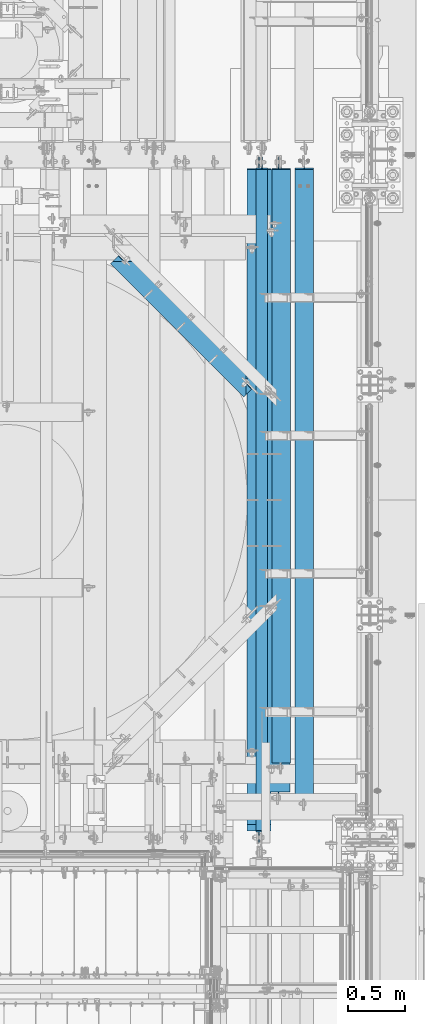
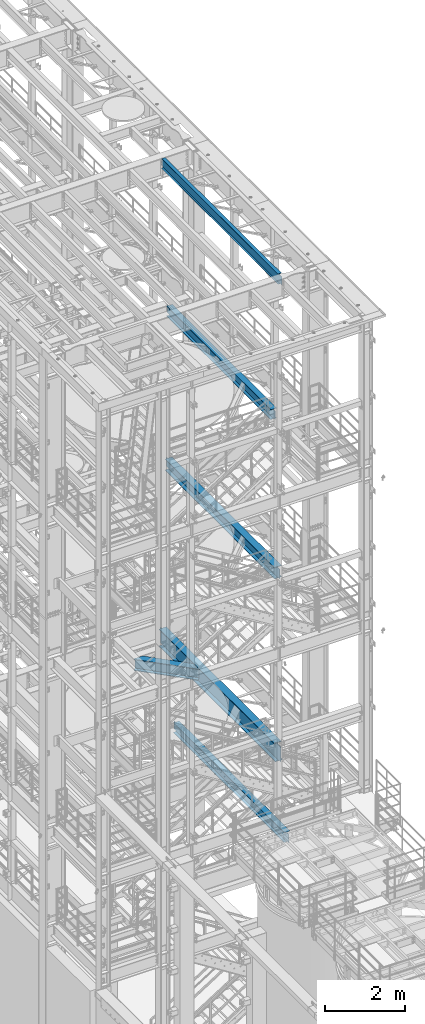
# One storey, part 1013 of 1876: 6 beams, 6 elements without a shape of their own.
"""IFC2X3 building model written with IfcOpenShell, lengths in millimetres."""

from ifc_helpers import new_model, si_unit, frame, origin_with_axes, place, context, subcontext, project, spatial, faceted_brep, material, type_object, element, aggregate, save


model = new_model("IFC2X3")

# Units and contexts
model_context = context("Model", 3, precision=1e-05, world=origin_with_axes())
body_context = subcontext(model_context, "Body", "Model", "MODEL_VIEW")
ifc_project = project(units=[si_unit("LENGTHUNIT", "METRE", prefix="MILLI"), si_unit("AREAUNIT", "SQUARE_METRE"), si_unit("VOLUMEUNIT", "CUBIC_METRE"), si_unit("MASSUNIT", "GRAM", prefix="KILO"), si_unit("TIMEUNIT", "SECOND"), si_unit("PLANEANGLEUNIT", "RADIAN"), si_unit("SOLIDANGLEUNIT", "STERADIAN"), si_unit("THERMODYNAMICTEMPERATUREUNIT", "DEGREE_CELSIUS"), si_unit("LUMINOUSINTENSITYUNIT", "LUMEN")], contexts=[model_context])

# Site, building, storey
site_placement = place(None, origin_with_axes())
site = spatial("IfcSite", under=ifc_project, at=site_placement, CompositionType="ELEMENT")
building_placement = place(site_placement, origin_with_axes())
building = spatial("IfcBuilding", under=site, at=building_placement, Name="Undefined", CompositionType="ELEMENT")
storey_placement = place(building_placement, origin_with_axes())
storey = spatial("IfcBuildingStorey", under=building, at=storey_placement, Name="Undefined", CompositionType="ELEMENT", Elevation=0.0)

# Assembly, beam
assembly_1_placement = place(storey_placement, origin_with_axes())
assembly_1 = element("IfcElementAssembly", 1, at=assembly_1_placement, inside=storey, Name="BEAM", AssemblyPlace="NOTDEFINED", PredefinedType="RIGID_FRAME")
ifc_material = material(Name="STEEL/A992")
beam_type_1 = type_object("IfcBeamType", Name="W12X16", PredefinedType="NOTDEFINED")
beam_1_placement = place(assembly_1_placement, frame((6667.5, -4572.0, 22402.8), z_axis=(0.0, 0.0, 1.0), x_axis=(0.0, 1.0, 0.0)))
beam_1 = element("IfcBeam", 2, at=beam_1_placement, type_object=beam_type_1, material=ifc_material, Name="BEAM", ObjectType="W12X16", context=body_context, shape_type="Brep", body=[
    faceted_brep([(19.84375, -3.17499999999995, -126.999999999996), (19.84375, 3.17499999999995, -126.999999999996), (102.393750190735, 3.17500000000018, -127.000000000001), (102.393750190735, -3.17500000000018, -127.000000000001), (107.25382970878, 3.17500000000018, -127.966729922588), (107.25382970878, -3.17500000000018, -127.966729922588), (111.374006176934, 3.17500000000018, -130.719743823067), (111.374006176934, -3.17500000000018, -130.719743823067), (114.127020077412, 3.17500000000018, -134.839920291221), (114.127020077412, -3.17500000000018, -134.839920291221), (115.09375, -3.17500000000018, -139.699999809266), (115.09375, 3.17500000000018, -139.699999809266), (115.09375, 3.17500000000018, -146.05), (115.09375, 50.8000000000002, -146.05), (115.09375, 50.8000000000002, -152.4), (115.09375, -50.8000000000002, -152.4), (115.09375, -50.8000000000002, -146.05), (115.09375, -3.17500000000018, -146.05), (127.79375, 3.17500000000018, 146.05), (127.79375, 50.8000000000002, 146.05), (5968.20625, 50.8, 146.05), (5968.20625, 3.17499999999995, 146.05), (115.093750190735, -3.17500000000018, 114.299999999999), (115.093750190735, 3.17500000000018, 114.299999999999), (19.84375, 3.17500000000018, 114.299999999999), (19.84375, -3.17500000000018, 114.299999999999), (119.95382970878, -3.17500000000018, 115.266729922587), (119.95382970878, 3.17500000000018, 115.266729922587), (124.074006176934, -3.17500000000018, 118.019743823065), (124.074006176934, 3.17500000000018, 118.019743823065), (126.827020077412, -3.17500000000018, 122.139920291219), (126.827020077412, 3.17500000000018, 122.139920291219), (127.79375, -3.17500000000018, 126.999999809264), (127.79375, 3.17500000000018, 126.999999809264), (127.79375, 50.8000000000002, 152.4), (127.79375, -50.8000000000002, 152.4), (5968.20625, -50.8, 152.4), (5968.20625, 50.8, 152.4), (127.79375, -50.8000000000002, 146.05), (5968.20625, -50.8, 146.05), (127.79375, -3.17500000000018, 146.05), (5968.20625, -3.17499999999995, 146.05), (5968.20625, -3.17499999999995, 126.999999809264), (5968.20625, 3.17499999999995, 126.999999809264), (5969.17297992259, -3.17499999999995, 122.139920291219), (5969.17297992259, 3.17499999999995, 122.139920291219), (5971.92599382307, -3.17499999999995, 118.019743823065), (5971.92599382307, 3.17499999999995, 118.019743823065), (5976.04617029122, -3.17499999999995, 115.266729922587), (5976.04617029122, 3.17499999999995, 115.266729922587), (5980.90624980927, -3.17499999999995, 114.299999999999), (5980.90624980927, 3.17499999999995, 114.299999999999), (6076.15625, -3.17499999999995, 114.299999999999), (6076.15625, 3.17499999999995, 114.299999999999), (6076.15625, -3.17499999999995, -126.999999999996), (6076.15625, 3.17499999999995, -126.999999999996), (5993.60624980927, -3.17499999999995, -127.000000000001), (5993.60624980927, 3.17499999999995, -127.000000000001), (5988.74617029122, -3.17499999999995, -127.966729922588), (5988.74617029122, 3.17499999999995, -127.966729922588), (5984.62599382307, -3.17499999999995, -130.719743823067), (5984.62599382307, 3.17499999999995, -130.719743823067), (5981.87297992259, -3.17499999999995, -134.839920291221), (5981.87297992259, 3.17499999999995, -134.839920291221), (5980.90625, -3.17499999999995, -139.699999809266), (5980.90625, 3.17499999999995, -139.699999809266), (5980.90625, -3.17499999999995, -146.05), (5980.90625, -50.8, -146.05), (5980.90625, -50.8, -152.4), (5980.90625, 50.8, -152.4), (5980.90625, 50.8, -146.05), (5980.90625, 3.17499999999995, -146.05)], [[[0, 1, 2, 3]], [[3, 2, 4, 5]], [[5, 4, 6, 7]], [[7, 6, 8, 9]], [[10, 11, 12, 13, 14, 15, 16, 17]], [[9, 8, 11, 10]], [[18, 19, 20, 21]], [[22, 23, 24, 25]], [[26, 27, 23, 22]], [[28, 29, 27, 26]], [[30, 31, 29, 28]], [[32, 33, 31, 30]], [[34, 35, 36, 37]], [[35, 38, 39, 36]], [[38, 40, 41, 39]], [[35, 34, 19, 18, 33, 32, 40, 38]], [[19, 34, 37, 20]], [[36, 39, 41, 42, 43, 21, 20, 37]], [[44, 45, 43, 42]], [[46, 47, 45, 44]], [[48, 49, 47, 46]], [[50, 51, 49, 48]], [[52, 53, 51, 50]], [[53, 52, 54, 55]], [[54, 56, 57, 55]], [[58, 59, 57, 56]], [[60, 61, 59, 58]], [[62, 63, 61, 60]], [[64, 65, 63, 62]], [[66, 67, 68, 69, 70, 71, 65, 64]], [[17, 16, 67, 66]], [[16, 15, 68, 67]], [[15, 14, 69, 68]], [[14, 13, 70, 69]], [[13, 12, 71, 70]], [[59, 61, 63, 65, 71, 12, 11, 8, 6, 4, 2, 1, 24, 23, 27, 29, 31, 33, 18, 21, 43, 45, 47, 49, 51, 53, 55, 57]], [[25, 24, 1, 0]], [[52, 50, 48, 46, 44, 42, 41, 40, 32, 30, 28, 26, 22, 25, 0, 3, 5, 7, 9, 10, 17, 66, 64, 62, 60, 58, 56, 54]]]),
])
aggregate(assembly_1, [beam_1])

assembly_2_placement = place(storey_placement, origin_with_axes())
assembly_2 = element("IfcElementAssembly", 3, at=assembly_2_placement, inside=storey, Name="BEAM", AssemblyPlace="NOTDEFINED", PredefinedType="RIGID_FRAME")
beam_type_2 = type_object("IfcBeamType", Name="W12X30", PredefinedType="NOTDEFINED")
beam_2_placement = place(assembly_2_placement, frame((6838.94981327725, -3932.91243515872, 17826.0375), z_axis=(0.0, 0.0, 1.0), x_axis=(0.0, 1.0, 0.0)))
beam_2 = element("IfcBeam", 4, at=beam_2_placement, type_object=beam_type_2, material=ifc_material, Name="BEAM", ObjectType="W12X30", context=body_context, shape_type="Brep", body=[
    faceted_brep([(5.43743515872211, -3.17500000000018, -125.412500000006), (5.43743515872211, 3.17500000000018, -125.412500000006), (87.9874353494556, 3.17500000000018, -125.412500000006), (87.9874353494556, -3.17500000000018, -125.412500000006), (92.8475148675011, 3.17500000000018, -126.379229922593), (92.8475148675011, -3.17500000000018, -126.379229922593), (96.9676913356548, 3.17500000000018, -129.132243823071), (96.9676913356548, -3.17500000000018, -129.132243823071), (99.7207052361327, 3.17500000000018, -133.252420291225), (99.7207052361327, -3.17500000000018, -133.252420291225), (100.687435158721, -3.17500000000018, -138.112499809271), (100.687435158721, 3.17500000000018, -138.112499809271), (100.68743515872, 3.17500000000018, -146.049999999999), (100.68743515872, 82.5500000000002, -146.049999999999), (100.68743515872, 82.5500000000002, -157.162499999999), (100.68743515872, -82.5500000000002, -157.162499999999), (100.68743515872, -82.5500000000002, -146.049999999999), (100.68743515872, -3.17500000000018, -146.049999999999), (5329.11868515872, 82.5500000000002, 146.049999999999), (5329.11868515872, 3.17500000000018, 146.049999999999), (84.8124351587203, 3.17500000000018, 146.049999999999), (84.8124351587203, 82.5500000000002, 146.049999999999), (72.1124353494556, -3.17500000000018, 131.762499999997), (72.1124353494556, 3.17500000000018, 131.762499999997), (5.43743515872211, 3.17500000000018, 131.762499999997), (5.43743515872211, -3.17500000000018, 131.762499999997), (76.9725148675011, -3.17500000000018, 132.729229922585), (76.9725148675011, 3.17500000000018, 132.729229922585), (81.0926913356548, -3.17500000000018, 135.482243823062), (81.0926913356548, 3.17500000000018, 135.482243823062), (83.8457052361327, -3.17500000000018, 139.602420291216), (83.8457052361327, 3.17500000000018, 139.602420291216), (84.8124351587207, -3.17500000000018, 144.462499809262), (84.8124351587207, 3.17500000000018, 144.462499809262), (5329.11868515872, -82.5500000000002, 157.162499999999), (5329.11868515872, 82.5500000000002, 157.162499999999), (84.8124351587203, 82.5500000000002, 157.162499999999), (84.8124351587203, -82.5500000000002, 157.162499999999), (5329.11868515872, -82.5500000000002, 146.049999999999), (84.8124351587203, -82.5500000000002, 146.049999999999), (5329.11868515872, -3.17500000000018, 146.049999999999), (84.8124351587203, -3.17500000000018, 146.049999999999), (5329.11868515872, -3.17500000000018, 131.762499809269), (5329.11868515872, 3.17500000000018, 131.762499809269), (5330.08541508131, -3.17500000000018, 126.902420291222), (5330.08541508131, 3.17500000000018, 126.902420291222), (5332.83842898179, -3.17500000000018, 122.782243823069), (5332.83842898179, 3.17500000000018, 122.782243823069), (5336.95860544994, -3.17500000000018, 120.029229922591), (5336.95860544994, 3.17500000000018, 120.029229922591), (5341.81868496799, -3.17500000000018, 119.062500000004), (5341.81868496799, 3.17500000000018, 119.062500000004), (5437.06868515872, -3.17500000000018, 119.062500000004), (5437.06868515872, 3.17500000000018, 119.062500000004), (5437.06868515872, -3.17500000000018, -131.762499999997), (5437.06868515872, 3.17500000000018, -131.762499999997), (5348.16868496799, -3.17500000000018, -131.762499999997), (5348.16868496799, 3.17500000000018, -131.762499999997), (5343.30860544994, -3.17500000000018, -132.729229922585), (5343.30860544994, 3.17500000000018, -132.729229922585), (5339.18842898179, -3.17500000000018, -135.482243823062), (5339.18842898179, 3.17500000000018, -135.482243823062), (5336.43541508131, -3.17500000000018, -139.602420291216), (5336.43541508131, 3.17500000000018, -139.602420291216), (5335.46868515872, -3.17500000000018, -144.462499809262), (5335.46868515872, 3.17500000000018, -144.462499809262), (5335.46868515872, -3.17500000000018, -146.049999999999), (5335.46868515872, -82.5500000000002, -146.049999999999), (5335.46868515872, -82.5500000000002, -157.162499999999), (5335.46868515872, 82.5500000000002, -157.162499999999), (5335.46868515872, 82.5500000000002, -146.049999999999), (5335.46868515872, 3.17500000000018, -146.049999999999)], [[[0, 1, 2, 3]], [[3, 2, 4, 5]], [[5, 4, 6, 7]], [[7, 6, 8, 9]], [[10, 11, 12, 13, 14, 15, 16, 17]], [[9, 8, 11, 10]], [[18, 19, 20, 21]], [[22, 23, 24, 25]], [[26, 27, 23, 22]], [[28, 29, 27, 26]], [[30, 31, 29, 28]], [[32, 33, 31, 30]], [[34, 35, 36, 37]], [[38, 34, 37, 39]], [[40, 38, 39, 41]], [[37, 36, 21, 20, 33, 32, 41, 39]], [[35, 18, 21, 36]], [[34, 38, 40, 42, 43, 19, 18, 35]], [[44, 45, 43, 42]], [[46, 47, 45, 44]], [[48, 49, 47, 46]], [[50, 51, 49, 48]], [[52, 53, 51, 50]], [[53, 52, 54, 55]], [[54, 56, 57, 55]], [[58, 59, 57, 56]], [[60, 61, 59, 58]], [[62, 63, 61, 60]], [[64, 65, 63, 62]], [[66, 67, 68, 69, 70, 71, 65, 64]], [[67, 66, 17, 16]], [[68, 67, 16, 15]], [[69, 68, 15, 14]], [[70, 69, 14, 13]], [[71, 70, 13, 12]], [[6, 4, 2, 1, 24, 23, 27, 29, 31, 33, 20, 19, 43, 45, 47, 49, 51, 53, 55, 57, 59, 61, 63, 65, 71, 12, 11, 8]], [[25, 24, 1, 0]], [[66, 64, 62, 60, 58, 56, 54, 52, 50, 48, 46, 44, 42, 40, 41, 32, 30, 28, 26, 22, 25, 0, 3, 5, 7, 9, 10, 17]]]),
])
aggregate(assembly_2, [beam_2])

assembly_3_placement = place(storey_placement, origin_with_axes())
assembly_3 = element("IfcElementAssembly", 5, at=assembly_3_placement, inside=storey, Name="BEAM", AssemblyPlace="NOTDEFINED", PredefinedType="RIGID_FRAME")
beam_3_placement = place(assembly_3_placement, frame((7042.15, -4267.2, 4973.6375), z_axis=(0.0, 0.0, 1.0), x_axis=(0.0, 1.0, 0.0)))
beam_3 = element("IfcBeam", 6, at=beam_3_placement, type_object=beam_type_2, material=ifc_material, Name="BEAM", ObjectType="W12X30", context=body_context, shape_type="Brep", body=[
    faceted_brep([(15.875, -3.17500000000018, -131.762499999999), (15.875, 3.17500000000018, -131.762499999999), (98.4250001907349, 3.17500000000018, -131.762499999999), (98.4250001907349, -3.17500000000018, -131.762499999999), (103.28507970878, 3.17500000000018, -132.729229922586), (103.28507970878, -3.17500000000018, -132.729229922586), (107.405256176934, 3.17500000000018, -135.482243823065), (107.405256176934, -3.17500000000018, -135.482243823065), (110.158270077412, 3.17500000000018, -139.602420291219), (110.158270077412, -3.17500000000018, -139.602420291219), (111.125, -3.17500000000018, -144.462499809264), (111.125, 3.17500000000018, -144.462499809264), (111.124999999998, 3.17500000000018, -146.049999999999), (111.125, 82.5500000000002, -146.05), (111.125, 82.5500000000002, -157.1625), (111.125, -82.5500000000002, -157.1625), (111.125, -82.5500000000002, -146.05), (111.124999999998, -3.17500000000018, -146.049999999999), (5663.40625, 82.5500000000002, 146.05), (5663.40625, 3.17500000000018, 146.05), (95.2499999999982, 3.17500000000018, 146.049999999999), (95.25, 82.5500000000002, 146.05), (82.5500001907349, -3.17500000000018, 131.762500000001), (82.5500001907349, 3.17500000000018, 131.762500000001), (15.875, 3.17500000000018, 131.762500000001), (15.875, -3.17500000000018, 131.762500000001), (87.4100797087804, -3.17500000000018, 132.729229922588), (87.4100797087804, 3.17500000000018, 132.729229922588), (91.530256176934, -3.17500000000018, 135.482243823067), (91.530256176934, 3.17500000000018, 135.482243823067), (94.2832700774125, -3.17500000000018, 139.60242029122), (94.2832700774125, 3.17500000000018, 139.60242029122), (95.25, -3.17500000000018, 144.462499809266), (95.25, 3.17500000000018, 144.462499809266), (5663.40625, -82.5500000000002, 157.1625), (5663.40625, 82.5500000000002, 157.1625), (95.25, 82.5500000000002, 157.1625), (95.25, -82.5500000000002, 157.1625), (5663.40625, -82.5500000000002, 146.05), (95.25, -82.5500000000002, 146.05), (5663.40625, -3.17500000000018, 146.05), (95.2499999999982, -3.17500000000018, 146.049999999999), (5663.40625, -3.17500000000018, 131.762499809264), (5663.40625, 3.17500000000018, 131.762499809264), (5664.37297992259, -3.17500000000018, 126.902420291219), (5664.37297992259, 3.17500000000018, 126.902420291219), (5667.12599382307, -3.17500000000018, 122.782243823065), (5667.12599382307, 3.17500000000018, 122.782243823065), (5671.24617029122, -3.17500000000018, 120.029229922587), (5671.24617029122, 3.17500000000018, 120.029229922587), (5676.10624980927, -3.17500000000018, 119.062499999999), (5676.10624980927, 3.17500000000018, 119.062499999999), (5771.35625, -3.17500000000018, 119.062499999999), (5771.35625, 3.17500000000018, 119.062499999999), (5771.35625, -3.17500000000018, -131.762500000001), (5771.35625, 3.17500000000018, -131.762500000001), (5688.80624980926, -3.17500000000018, -131.762500000001), (5688.80624980926, 3.17500000000018, -131.762500000001), (5683.94617029122, -3.17500000000018, -132.729229922588), (5683.94617029122, 3.17500000000018, -132.729229922588), (5679.82599382307, -3.17500000000018, -135.482243823067), (5679.82599382307, 3.17500000000018, -135.482243823067), (5677.07297992259, -3.17500000000018, -139.60242029122), (5677.07297992259, 3.17500000000018, -139.60242029122), (5676.10625, -3.17500000000018, -144.462499809266), (5676.10625, 3.17500000000018, -144.462499809266), (5676.10625, -3.17500000000018, -146.05), (5676.10625, -82.5500000000002, -146.05), (5676.10625, -82.5500000000002, -157.1625), (5676.10625, 82.5500000000002, -157.1625), (5676.10625, 82.5500000000002, -146.05), (5676.10625, 3.17500000000018, -146.05)], [[[0, 1, 2, 3]], [[3, 2, 4, 5]], [[5, 4, 6, 7]], [[7, 6, 8, 9]], [[10, 11, 12, 13, 14, 15, 16, 17]], [[9, 8, 11, 10]], [[18, 19, 20, 21]], [[22, 23, 24, 25]], [[26, 27, 23, 22]], [[28, 29, 27, 26]], [[30, 31, 29, 28]], [[32, 33, 31, 30]], [[34, 35, 36, 37]], [[38, 34, 37, 39]], [[40, 38, 39, 41]], [[37, 36, 21, 20, 33, 32, 41, 39]], [[35, 18, 21, 36]], [[34, 38, 40, 42, 43, 19, 18, 35]], [[44, 45, 43, 42]], [[46, 47, 45, 44]], [[48, 49, 47, 46]], [[50, 51, 49, 48]], [[52, 53, 51, 50]], [[53, 52, 54, 55]], [[54, 56, 57, 55]], [[58, 59, 57, 56]], [[60, 61, 59, 58]], [[62, 63, 61, 60]], [[64, 65, 63, 62]], [[66, 67, 68, 69, 70, 71, 65, 64]], [[67, 66, 17, 16]], [[68, 67, 16, 15]], [[69, 68, 15, 14]], [[70, 69, 14, 13]], [[71, 70, 13, 12]], [[6, 4, 2, 1, 24, 23, 27, 29, 31, 33, 20, 19, 43, 45, 47, 49, 51, 53, 55, 57, 59, 61, 63, 65, 71, 12, 11, 8]], [[25, 24, 1, 0]], [[66, 64, 62, 60, 58, 56, 54, 52, 50, 48, 46, 44, 42, 40, 41, 32, 30, 28, 26, 22, 25, 0, 3, 5, 7, 9, 10, 17]]]),
])
aggregate(assembly_3, [beam_3])

assembly_4_placement = place(storey_placement, origin_with_axes())
assembly_4 = element("IfcElementAssembly", 7, at=assembly_4_placement, inside=storey, Name="BEAM", AssemblyPlace="NOTDEFINED", PredefinedType="RIGID_FRAME")
beam_type_3 = type_object("IfcBeamType", Name="W14X48", PredefinedType="NOTDEFINED")
beam_4_placement = place(assembly_4_placement, frame((6642.09999997612, -607.950268509526, 7978.775), z_axis=(0.0, 0.0, 1.0), x_axis=(-0.707106781186548, 0.707106781186547, 0.0)))
beam_4 = element("IfcBeam", 8, at=beam_4_placement, type_object=beam_type_3, material=ifc_material, Name="BEAM", ObjectType="W14X48", context=body_context, shape_type="Brep", body=[
    faceted_brep([(90.9649929080092, -3.96875, -158.75), (90.9649917881488, -3.96793732113392, -174.625), (185.657550468893, -3.96810879993049, -174.625), (185.657550466564, -3.96874999997075, -158.75), (185.657373667258, -101.599999999957, -158.75), (185.657373667258, -101.599999999957, -174.625), (90.9649917881488, 101.6, -174.625), (90.9649917881488, 101.6, -158.75), (1756.91569490771, 101.600000000099, -158.75), (1756.91569490771, 101.600000000099, -174.625), (90.9649929080101, 3.96875000000273, -158.75), (1756.91569490769, 3.96875000008913, -158.75), (90.9649917881488, 101.6, 158.75), (90.9649917881488, 101.6, 174.625), (1756.91569490771, 101.600000000099, 174.625), (1756.91569490771, 101.600000000099, 158.75), (1756.91569490771, 75.1697674114184, 174.625), (1756.9156949077, 75.1697674114175, 158.75), (1580.14586216267, -101.599999836176, 174.625), (1580.14586199891, -101.59999999993, 158.75), (1677.77714817365, -3.96874999991542, 158.75), (1677.77714817365, -3.96874999991542, 155.574999809265), (1685.71465111468, 3.96875000008549, 155.574999809265), (1685.71465111468, 3.96875000008549, 158.75), (1679.14431099461, -3.96874999991542, 150.71492029122), (1687.08181393564, 3.9687500000864, 150.71492029122), (1683.03766131136, -3.96874999991542, 146.594743823066), (1690.97516425239, 3.96875000008549, 146.594743823066), (1688.86447183148, -3.96874999991451, 143.841729922588), (1696.80197477251, 3.9687500000864, 143.841729922588), (1695.73766347345, -3.96874999991451, 142.875), (1703.67516641449, 3.9687500000864, 142.875), (1756.91569490769, -3.96874999991178, 142.875), (1756.91569490769, 3.96875000008913, 142.875), (1756.91569490769, -3.96874999991178, 137.26499743964), (1756.91569490769, -3.96874999991178, -92.8150096229674), (1756.91569490769, -3.96874999991178, -149.232884269973), (1756.91569490769, -3.96874999991178, -158.75), (1756.91569490769, -3.96956320504069, -174.625), (1662.22316177964, -3.96874999991542, -158.75), (1662.22316177733, -3.96939219499291, -174.625), (1662.22298546119, -101.599999912207, -158.75), (1662.22298546119, -101.599999999927, -174.625), (90.9649917881488, -3.96874999998576, -149.233551893037), (90.9649917881488, -3.96874999998576, -92.8150055768701), (90.9649917881488, -3.96874999998576, 137.265008229234), (90.9649929080092, -3.96875, 142.875), (90.9649929080101, 3.96875000000273, 142.875), (152.142945789183, -3.96874999997598, 142.875), (144.205448449586, 3.96875000002152, 142.875), (159.016135005973, -3.96874999997507, 143.841729922588), (151.078637666375, 3.96875000002265, 143.841729922588), (164.842943470122, -3.96874999997394, 146.594743823066), (156.905446130525, 3.96875000002356, 146.594743823066), (168.736292413114, -3.96874999997326, 150.71492029122), (160.798795073517, 3.96875000002424, 150.71492029122), (170.103454751674, -3.96874999997326, 155.574999809265), (162.165957412077, 3.96875000002447, 155.574999809265), (162.165957412077, 3.9687500000247, 158.75), (90.9649917881488, 75.1697394882857, 158.75), (90.9649917881488, 75.1697394882857, 174.625), (267.73467202872, -101.599999999944, 174.625), (267.73467202872, -101.599999999944, 158.75), (170.103454751674, -3.96874999997326, 158.75)], [[[0, 1, 2, 3]], [[4, 3, 2, 5]], [[6, 7, 8, 9]], [[7, 10, 11, 8]], [[12, 13, 14, 15]], [[15, 14, 16, 17]], [[16, 18, 19, 20, 21, 22, 23, 17]], [[22, 21, 24, 25]], [[25, 24, 26, 27]], [[27, 26, 28, 29]], [[29, 28, 30, 31]], [[32, 33, 31, 30]], [[9, 8, 11, 33, 32, 34, 35, 36, 37, 38]], [[37, 39, 40, 38]], [[41, 42, 40, 39]], [[42, 41, 4, 5]], [[1, 6, 9, 38, 40, 42, 5, 2]], [[43, 44, 45, 46, 47, 10, 7, 6, 1, 0]], [[48, 49, 47, 46]], [[50, 51, 49, 48]], [[52, 53, 51, 50]], [[54, 55, 53, 52]], [[56, 57, 55, 54]], [[23, 22, 25, 27, 29, 31, 33, 11, 10, 47, 49, 51, 53, 55, 57, 58]], [[12, 15, 17, 23, 58, 59]], [[13, 12, 59, 60]], [[18, 16, 14, 13, 60, 61]], [[19, 18, 61, 62]], [[20, 19, 62, 63]], [[61, 60, 59, 58, 57, 56, 63, 62]], [[54, 52, 50, 48, 46, 45, 44, 43, 0, 3, 39, 37, 36, 35, 34, 32, 30, 28, 26, 24, 21, 20, 63, 56]], [[41, 39, 3, 4]]]),
])
aggregate(assembly_4, [beam_4])

assembly_5_placement = place(storey_placement, origin_with_axes())
assembly_5 = element("IfcElementAssembly", 9, at=assembly_5_placement, inside=storey, Name="BEAM", AssemblyPlace="NOTDEFINED", PredefinedType="RIGID_FRAME")
beam_5_placement = place(assembly_5_placement, frame((6813.55, -4216.003125, 13134.975), z_axis=(0.0, 0.0, 1.0), x_axis=(0.0, 1.0, 0.0)))
beam_5 = element("IfcBeam", 10, at=beam_5_placement, type_object=beam_type_3, material=ifc_material, Name="BEAM", ObjectType="W14X48", context=body_context, shape_type="Brep", body=[
    faceted_brep([(16.668749999998, -3.96875, -142.875), (16.668749999998, 3.96875, -142.875), (99.218750190732, 3.96875, -142.875), (99.218750190732, -3.96875, -142.875), (104.078829708777, 3.96875, -143.841729922588), (104.078829708777, -3.96875, -143.841729922588), (108.199006176931, 3.96875, -146.594743823065), (108.199006176931, -3.96875, -146.594743823065), (110.95202007741, 3.96875, -150.714920291219), (110.95202007741, -3.96875, -150.714920291219), (111.918749999997, -3.96875, -155.574999809265), (111.918749999997, 3.96875, -155.574999809265), (111.918749999997, 3.96875, -158.75), (111.918749999997, 101.6, -158.75), (111.918749999997, 101.6, -174.625), (111.918749999997, -101.6, -174.625), (111.918749999997, -101.6, -158.75), (111.918749999997, -3.96875, -158.75), (5609.034375, 101.6, 158.75), (5609.034375, 3.96875, 158.75), (115.093749999997, 3.96875, 158.75), (115.093749999997, 101.6, 158.75), (102.393750190732, -3.96875, 142.875), (102.393750190732, 3.96875, 142.875), (16.668749999998, 3.96875, 142.875), (16.668749999998, -3.96875, 142.875), (107.253829708778, -3.96875, 143.841729922588), (107.253829708778, 3.96875, 143.841729922588), (111.374006176931, -3.96875, 146.594743823065), (111.374006176931, 3.96875, 146.594743823065), (114.12702007741, -3.96875, 150.714920291219), (114.12702007741, 3.96875, 150.714920291219), (115.093749999997, -3.96875, 155.574999809265), (115.093749999997, 3.96875, 155.574999809265), (5609.034375, -101.6, 174.625), (5609.034375, 101.6, 174.625), (115.093749999997, 101.6, 174.625), (115.093749999997, -101.6, 174.625), (5609.034375, -101.6, 158.75), (115.093749999997, -101.6, 158.75), (5609.034375, -3.96875, 158.75), (115.093749999997, -3.96875, 158.75), (5609.034375, -3.96875, 149.224999809265), (5609.034375, 3.96875, 149.224999809265), (5610.00110492259, -3.96875, 144.364920291218), (5610.00110492259, 3.96875, 144.364920291218), (5612.75411882307, -3.96875, 140.244743823065), (5612.75411882307, 3.96875, 140.244743823065), (5616.87429529122, -3.96875, 137.491729922587), (5616.87429529122, 3.96875, 137.491729922587), (5621.73437480927, -3.96875, 136.525), (5621.73437480927, 3.96875, 136.525), (5720.159375, -3.96875, 136.525), (5720.159375, 3.96875, 136.525), (5720.159375, -3.96875, -142.875), (5720.159375, 3.96875, -142.875), (5621.73437480927, -3.96875, -142.875), (5621.73437480927, 3.96875, -142.875), (5616.87429529122, -3.96875, -143.841729922588), (5616.87429529122, 3.96875, -143.841729922588), (5612.75411882307, -3.96875, -146.594743823065), (5612.75411882307, 3.96875, -146.594743823065), (5610.00110492259, -3.96875, -150.714920291219), (5610.00110492259, 3.96875, -150.714920291219), (5609.034375, -3.96875, -155.574999809265), (5609.034375, 3.96875, -155.574999809265), (5609.034375, -3.96875, -158.75), (5609.034375, -101.6, -158.75), (5609.034375, -101.6, -174.625), (5609.034375, 101.6, -174.625), (5609.034375, 101.6, -158.75), (5609.034375, 3.96875, -158.75)], [[[0, 1, 2, 3]], [[3, 2, 4, 5]], [[5, 4, 6, 7]], [[7, 6, 8, 9]], [[10, 11, 12, 13, 14, 15, 16, 17]], [[9, 8, 11, 10]], [[18, 19, 20, 21]], [[22, 23, 24, 25]], [[26, 27, 23, 22]], [[28, 29, 27, 26]], [[30, 31, 29, 28]], [[32, 33, 31, 30]], [[34, 35, 36, 37]], [[38, 34, 37, 39]], [[40, 38, 39, 41]], [[37, 36, 21, 20, 33, 32, 41, 39]], [[35, 18, 21, 36]], [[34, 38, 40, 42, 43, 19, 18, 35]], [[44, 45, 43, 42]], [[46, 47, 45, 44]], [[48, 49, 47, 46]], [[50, 51, 49, 48]], [[52, 53, 51, 50]], [[53, 52, 54, 55]], [[54, 56, 57, 55]], [[58, 59, 57, 56]], [[60, 61, 59, 58]], [[62, 63, 61, 60]], [[64, 65, 63, 62]], [[66, 67, 68, 69, 70, 71, 65, 64]], [[67, 66, 17, 16]], [[68, 67, 16, 15]], [[69, 68, 15, 14]], [[70, 69, 14, 13]], [[71, 70, 13, 12]], [[6, 4, 2, 1, 24, 23, 27, 29, 31, 33, 20, 19, 43, 45, 47, 49, 51, 53, 55, 57, 59, 61, 63, 65, 71, 12, 11, 8]], [[25, 24, 1, 0]], [[66, 64, 62, 60, 58, 56, 54, 52, 50, 48, 46, 44, 42, 40, 41, 32, 30, 28, 26, 22, 25, 0, 3, 5, 7, 9, 10, 17]]]),
])
aggregate(assembly_5, [beam_5])

assembly_6_placement = place(storey_placement, origin_with_axes())
assembly_6 = element("IfcElementAssembly", 11, at=assembly_6_placement, inside=storey, Name="BEAM", AssemblyPlace="NOTDEFINED", PredefinedType="RIGID_FRAME")
beam_type_4 = type_object("IfcBeamType", Name="W21X68", PredefinedType="NOTDEFINED")
beam_6_placement = place(assembly_6_placement, frame((6642.09999997612, -4572.00000540753, 7885.1125), z_axis=(0.0, 0.0, 1.0), x_axis=(0.0, 1.0, 0.0)))
beam_6 = element("IfcBeam", 12, at=beam_6_placement, type_object=beam_type_4, material=ifc_material, Name="BEAM", ObjectType="W21X68", context=body_context, shape_type="Brep", body=[
    faceted_brep([(23.0187554075283, -5.55624999999964, -242.8875), (23.0187554075283, 5.55624999999964, -242.8875), (111.918755598262, 5.55624999999964, -242.8875), (111.918755598262, -5.55624999999964, -242.8875), (116.778835116307, 5.55624999999964, -243.854229922587), (116.778835116307, -5.55624999999964, -243.854229922587), (120.899011584461, 5.55624999999964, -246.607243823066), (120.899011584461, -5.55624999999964, -246.607243823066), (123.652025484939, 5.55624999999964, -250.825), (123.652025484939, -5.55624999999964, -250.825), (124.618755407527, -104.775, -255.587499809265), (124.618755407527, 104.775, -255.587499809265), (124.618755407527, 104.775, -268.2875), (124.618755407527, -104.775, -268.2875), (123.652025484939, -104.775, -250.825), (123.652025484939, 104.775, -250.825), (5968.20625540753, 104.775, 250.825), (5968.20625540753, 5.55624999999964, 250.825), (181.768755407526, 5.55624999999964, 250.825), (181.768755407526, 104.775, 250.825), (169.068755598261, -5.55624999999964, 217.4875), (169.068755598261, 5.55624999999964, 217.4875), (23.0187554075283, 5.55624999999964, 217.4875), (23.0187554075283, -5.55624999999964, 217.4875), (173.928835116307, -5.55624999999964, 218.454229922588), (173.928835116307, 5.55624999999964, 218.454229922588), (178.04901158446, -5.55624999999964, 221.207243823066), (178.04901158446, 5.55624999999964, 221.207243823066), (180.802025484939, -5.55624999999964, 225.32742029122), (180.802025484939, 5.55624999999964, 225.32742029122), (181.768755407526, -5.55624999999964, 230.187499809265), (181.768755407526, 5.55624999999964, 230.187499809265), (5968.20625540753, -104.775, 268.2875), (5968.20625540753, 104.775, 268.2875), (181.768755407526, 104.775, 268.2875), (181.768755407526, -104.775, 268.2875), (5968.20625540753, -104.775, 250.825), (181.768755407526, -104.775, 250.825), (5968.20625540753, -5.55624999999964, 250.825), (181.768755407526, -5.55624999999964, 250.825), (5968.20625540753, -5.55624999999964, 242.887499809264), (5968.20625540753, 5.55624999999964, 242.887499809264), (5969.17298533012, -5.55624999999964, 238.027420291219), (5969.17298533012, 5.55624999999964, 238.027420291219), (5971.92599923059, -5.55624999999964, 233.907243823065), (5971.92599923059, 5.55624999999964, 233.907243823065), (5976.04617569875, -5.55624999999964, 231.154229922587), (5976.04617569875, 5.55624999999964, 231.154229922587), (5980.90625521679, -5.55624999999964, 230.187499999999), (5980.90625521679, 5.55624999999964, 230.187499999999), (6076.15625540753, -5.55624999999964, 230.187499999999), (6076.15625540753, 5.55624999999964, 230.187499999999), (6076.15625540753, -5.55624999999964, -242.887500000001), (6076.15625540753, 5.55624999999964, -242.887500000001), (5987.25625521679, -5.55624999999964, -242.887500000001), (5987.25625521679, 5.55624999999964, -242.887500000001), (5982.39617569875, -5.55624999999964, -243.854229922588), (5982.39617569875, 5.55624999999964, -243.854229922588), (5978.27599923059, -5.55624999999964, -246.607243823067), (5978.27599923059, 5.55624999999964, -246.607243823067), (5975.52298533012, -5.55624999999964, -250.825), (5975.52298533012, 5.55624999999964, -250.825), (5975.52298533012, -104.775, -250.825), (5974.55625540753, -104.775, -255.587499809266), (5974.55625540753, 104.775, -255.587499809266), (5975.52298533012, 104.775, -250.825), (5974.55625540753, -104.775, -268.2875), (5974.55625540753, 104.775, -268.2875)], [[[0, 1, 2, 3]], [[3, 2, 4, 5]], [[5, 4, 6, 7]], [[7, 6, 8, 9]], [[10, 11, 12, 13]], [[14, 9, 8, 15, 11, 10]], [[16, 17, 18, 19]], [[20, 21, 22, 23]], [[24, 25, 21, 20]], [[26, 27, 25, 24]], [[28, 29, 27, 26]], [[30, 31, 29, 28]], [[32, 33, 34, 35]], [[36, 32, 35, 37]], [[38, 36, 37, 39]], [[35, 34, 19, 18, 31, 30, 39, 37]], [[33, 16, 19, 34]], [[32, 36, 38, 40, 41, 17, 16, 33]], [[42, 43, 41, 40]], [[44, 45, 43, 42]], [[46, 47, 45, 44]], [[48, 49, 47, 46]], [[50, 51, 49, 48]], [[51, 50, 52, 53]], [[52, 54, 55, 53]], [[56, 57, 55, 54]], [[58, 59, 57, 56]], [[60, 61, 59, 58]], [[62, 63, 64, 65, 61, 60]], [[66, 67, 64, 63]], [[67, 66, 13, 12]], [[65, 64, 67, 12, 11, 15]], [[61, 65, 15, 8]], [[4, 2, 1, 22, 21, 25, 27, 29, 31, 18, 17, 41, 43, 45, 47, 49, 51, 53, 55, 57, 59, 61, 8, 6]], [[23, 22, 1, 0]], [[60, 58, 56, 54, 52, 50, 48, 46, 44, 42, 40, 38, 39, 30, 28, 26, 24, 20, 23, 0, 3, 5, 7, 9]], [[62, 60, 9, 14]], [[66, 63, 62, 14, 10, 13]]]),
])
aggregate(assembly_6, [beam_6])

save(model, "model.ifc")
